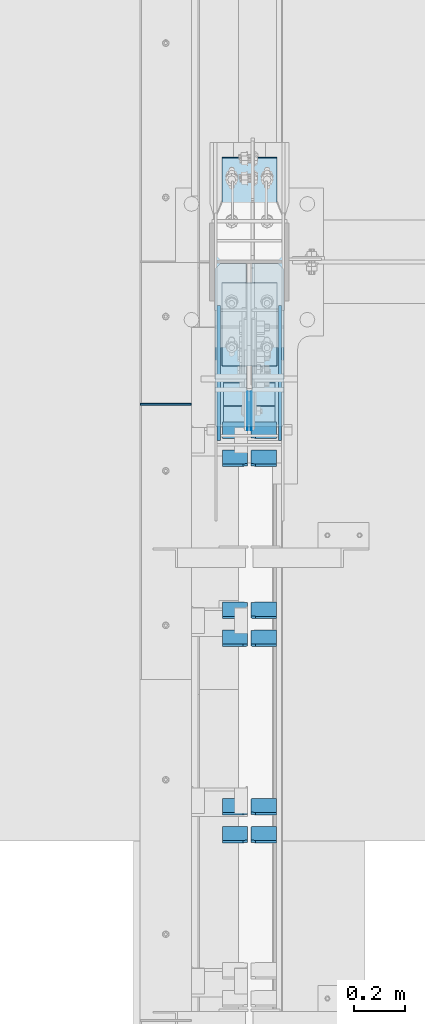
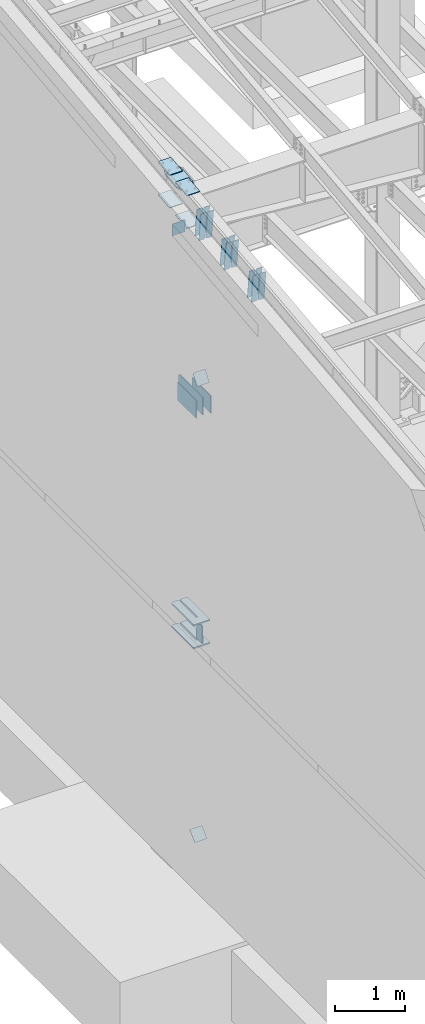
# One storey, part 1015 of 1179: 27 plates, 6 elements without a shape of their own.
"""IFC2X3 building model written with IfcOpenShell, lengths in millimetres."""

from ifc_helpers import new_model, si_unit, frame, origin_with_axes, place, context, subcontext, project, spatial, faceted_brep, material, type_object, element, aggregate, save


model = new_model("IFC2X3")

# Units and contexts
model_context = context("Model", 3, precision=1e-05, world=origin_with_axes())
body_context = subcontext(model_context, "Body", "Model", "MODEL_VIEW")
ifc_project = project(units=[si_unit("LENGTHUNIT", "METRE", prefix="MILLI"), si_unit("AREAUNIT", "SQUARE_METRE"), si_unit("VOLUMEUNIT", "CUBIC_METRE"), si_unit("MASSUNIT", "GRAM", prefix="KILO"), si_unit("TIMEUNIT", "SECOND"), si_unit("PLANEANGLEUNIT", "RADIAN"), si_unit("SOLIDANGLEUNIT", "STERADIAN"), si_unit("THERMODYNAMICTEMPERATUREUNIT", "DEGREE_CELSIUS"), si_unit("LUMINOUSINTENSITYUNIT", "LUMEN")], contexts=[model_context])

# Site, building, storey
site_placement = place(None, origin_with_axes())
site = spatial("IfcSite", under=ifc_project, at=site_placement, CompositionType="ELEMENT")
building_placement = place(site_placement, origin_with_axes())
building = spatial("IfcBuilding", under=site, at=building_placement, Name="Undefined", CompositionType="ELEMENT")
storey_placement = place(building_placement, origin_with_axes())
storey = spatial("IfcBuildingStorey", under=building, at=storey_placement, Name="Undefined", CompositionType="ELEMENT", Elevation=0.0)

# Assembly, plates
assembly_1_placement = place(storey_placement, origin_with_axes())
assembly_1 = element("IfcElementAssembly", 1, at=assembly_1_placement, inside=storey, Name="COLUMN", AssemblyPlace="NOTDEFINED", PredefinedType="RIGID_FRAME")
ifc_material_1 = material(Name="STEEL/A572-GR.50")
plate_type_1 = type_object("IfcPlateType", PredefinedType="NOTDEFINED")
plate_1_placement = place(assembly_1_placement, frame((295.275012207031, 18575.0015696625, 3694.1125), z_axis=(0.0, 1.0, 0.0), x_axis=(1.0, 0.0, 0.0)))
plate_1 = element("IfcPlate", 2, at=plate_1_placement, type_object=plate_type_1, material=ifc_material_1, Name="PLATE", context=body_context, shape_type="Brep", body=[
    faceted_brep([(125.412487792968, -11.1125000000002, 646.448430322878), (125.412487792968, -11.1125000000002, 153.987500190735), (125.412487792968, 11.1125000000002, 153.987500190735), (125.412487792968, 11.1125000000002, 646.448430322878), (126.258376502454, -11.1125000000002, 149.734930475586), (126.258376502454, 11.1125000000002, 149.734930475586), (128.667263742896, -11.1125000000002, 146.12977594993), (128.667263742896, 11.1125000000002, 146.12977594993), (132.272418268556, -11.1125000000002, 143.720888709488), (132.272418268556, 11.1125000000002, 143.720888709488), (136.524987602239, -11.1125000000002, 142.875), (136.524987602239, 11.1125000000002, 142.875), (140.777557317386, -11.1125000000002, 143.720888709488), (140.777557317386, 11.1125000000002, 143.720888709488), (144.382711843045, -11.1125000000002, 146.12977594993), (144.382711843045, 11.1125000000002, 146.12977594993), (146.791599083488, -11.1125000000002, 149.734930475586), (146.791599083488, 11.1125000000002, 149.734930475586), (147.637487792974, -11.1125000000002, 153.987500190735), (147.637487792974, 11.1125000000002, 153.987500190735), (147.637487792974, -11.1125000000002, 646.448430322878), (147.637487792974, 11.1125000000002, 646.448430322878), (0.0, -11.1125000000002, 624.223429941409), (22.2250003814697, -11.1125000000002, 646.448430322878), (22.2250003814697, 11.1125000000002, 646.448430322878), (0.0, 11.1125000000002, 624.223429941409), (0.0, -11.1125000000002, 15.875), (0.0, 11.1125000000002, 15.875), (6.34999990463257, -11.1125000000002, 0.0), (6.34999990463257, 11.1125000000002, 0.0), (266.699987888336, -11.1125000000002, 0.0), (266.699987888336, 11.1125000000002, 0.0), (273.049987792969, -11.1125000000002, 15.875), (273.049987792969, 11.1125000000002, 15.875), (273.049987792969, -11.1125000000002, 624.223429941409), (273.049987792969, 11.1125000000002, 624.223429941409), (250.824987411499, -11.1125000000002, 646.448430322878), (250.824987411499, 11.1125000000002, 646.448430322878)], [[[0, 1, 2, 3]], [[4, 5, 2, 1]], [[6, 7, 5, 4]], [[8, 9, 7, 6]], [[10, 11, 9, 8]], [[12, 13, 11, 10]], [[14, 15, 13, 12]], [[16, 17, 15, 14]], [[18, 19, 17, 16]], [[20, 21, 19, 18]], [[22, 23, 24, 25]], [[26, 22, 25, 27]], [[28, 26, 27, 29]], [[30, 28, 29, 31]], [[32, 30, 31, 33]], [[34, 32, 33, 35]], [[36, 34, 35, 37]], [[16, 14, 12, 10, 8, 6, 4, 1, 0, 23, 22, 26, 28, 30, 32, 34, 36, 20, 18]], [[24, 23, 0, 3]], [[37, 35, 33, 31, 29, 27, 25, 24, 3, 2, 5, 7, 9, 11, 13, 15, 17, 19, 21]], [[36, 37, 21, 20]]]),
])
plate_2_placement = place(assembly_1_placement, frame((295.275012207031, 18575.0015696625, 4090.9875), z_axis=(0.0, 1.0, 0.0), x_axis=(1.0, 0.0, 0.0)))
plate_2 = element("IfcPlate", 3, at=plate_2_placement, type_object=plate_type_1, material=ifc_material_1, Name="PLATE", context=body_context, shape_type="Brep", body=[
    faceted_brep([(125.412487792968, -11.1125000000002, 646.448430322878), (125.412487792968, -11.1125000000002, 153.987500190735), (125.412487792968, 11.1125000000002, 153.987500190735), (125.412487792968, 11.1125000000002, 646.448430322878), (126.258376502454, -11.1125000000002, 149.734930475586), (126.258376502454, 11.1125000000002, 149.734930475586), (128.667263742896, -11.1125000000002, 146.12977594993), (128.667263742896, 11.1125000000002, 146.12977594993), (132.272418268556, -11.1125000000002, 143.720888709488), (132.272418268556, 11.1125000000002, 143.720888709488), (136.524987602239, -11.1125000000002, 142.875), (136.524987602239, 11.1125000000002, 142.875), (140.777557317386, -11.1125000000002, 143.720888709488), (140.777557317386, 11.1125000000002, 143.720888709488), (144.382711843045, -11.1125000000002, 146.12977594993), (144.382711843045, 11.1125000000002, 146.12977594993), (146.791599083488, -11.1125000000002, 149.734930475586), (146.791599083488, 11.1125000000002, 149.734930475586), (147.637487792974, -11.1125000000002, 153.987500190735), (147.637487792974, 11.1125000000002, 153.987500190735), (147.637487792974, -11.1125000000002, 646.448430322878), (147.637487792974, 11.1125000000002, 646.448430322878), (0.0, -11.1125000000002, 624.223429941409), (22.2250003814697, -11.1125000000002, 646.448430322878), (22.2250003814697, 11.1125000000002, 646.448430322878), (0.0, 11.1125000000002, 624.223429941409), (0.0, -11.1125000000002, 15.875), (0.0, 11.1125000000002, 15.875), (6.34999990463257, -11.1125000000002, 0.0), (6.34999990463257, 11.1125000000002, 0.0), (266.699987888336, -11.1125000000002, 0.0), (266.699987888336, 11.1125000000002, 0.0), (273.049987792969, -11.1125000000002, 15.875), (273.049987792969, 11.1125000000002, 15.875), (273.049987792969, -11.1125000000002, 624.223429941409), (273.049987792969, 11.1125000000002, 624.223429941409), (250.824987411499, -11.1125000000002, 646.448430322878), (250.824987411499, 11.1125000000002, 646.448430322878)], [[[0, 1, 2, 3]], [[4, 5, 2, 1]], [[6, 7, 5, 4]], [[8, 9, 7, 6]], [[10, 11, 9, 8]], [[12, 13, 11, 10]], [[14, 15, 13, 12]], [[16, 17, 15, 14]], [[18, 19, 17, 16]], [[20, 21, 19, 18]], [[22, 23, 24, 25]], [[26, 22, 25, 27]], [[28, 26, 27, 29]], [[30, 28, 29, 31]], [[32, 30, 31, 33]], [[34, 32, 33, 35]], [[36, 34, 35, 37]], [[16, 14, 12, 10, 8, 6, 4, 1, 0, 23, 22, 26, 28, 30, 32, 34, 36, 20, 18]], [[24, 23, 0, 3]], [[37, 35, 33, 31, 29, 27, 25, 24, 3, 2, 5, 7, 9, 11, 13, 15, 17, 19, 21]], [[36, 37, 21, 20]]]),
])

# Assembly, plate
assembly_2_placement = place(storey_placement, origin_with_axes())
assembly_2 = element("IfcElementAssembly", 4, at=assembly_2_placement, inside=storey, Name="BEAM", AssemblyPlace="NOTDEFINED", PredefinedType="RIGID_FRAME")
ifc_material_2 = material(Name="STEEL/A36")
plate_type_2 = type_object("IfcPlateType", PredefinedType="NOTDEFINED")
plate_3_placement = place(assembly_2_placement, frame((0.0, 18665.8250005413, 11099.2055869157), z_axis=(0.0, 0.0, -1.0), x_axis=(1.0, 0.0, 0.0)))
plate_3 = element("IfcPlate", 5, at=plate_3_placement, type_object=plate_type_2, material=ifc_material_2, Name="CAP_PLATE", context=body_context, shape_type="Brep", body=[
    faceted_brep([(0.0, -3.17500000000109, 0.0), (0.0, -3.17499999999927, 204.492999998953), (0.0, 3.17499999999927, 204.492999998953), (0.0, 3.17500000000109, 7.27595761418343e-12), (203.199999999997, -3.17499999999927, 204.492999998953), (203.199999999997, 3.17499999999927, 204.492999998953), (203.199999999997, -3.17499999999927, 3.63797880709171e-12), (203.199999999997, 3.17499999999382, -3.63797880709171e-12)], [[[0, 1, 2, 3]], [[1, 4, 5, 2]], [[4, 6, 7, 5]], [[6, 0, 3, 7]], [[5, 7, 3, 2]], [[6, 4, 1, 0]]]),
])
aggregate(assembly_2, [plate_3])

assembly_3_placement = place(storey_placement, origin_with_axes())
assembly_3 = element("IfcElementAssembly", 6, at=assembly_3_placement, inside=storey, Name="Plate", AssemblyPlace="NOTDEFINED", PredefinedType="RIGID_FRAME")
plate_4_placement = place(assembly_3_placement, frame((330.200000000002, 18538.1072747927, 8241.67561343987), z_axis=(0.0, 0.591856615182528, 0.806043266248581), x_axis=(1.0, 0.0, 0.0)))
plate_4 = element("IfcPlate", 7, at=plate_4_placement, type_object=plate_type_2, material=ifc_material_2, Name="Plate", context=body_context, shape_type="Brep", body=[
    faceted_brep([(0.0, -3.17500000000109, 0.0), (0.0, -3.17500000000291, 203.200000000368), (0.0, 3.17499999998836, 203.200000000361), (0.0, 3.17500000000109, 7.27595761418343e-12), (203.199999999997, -3.17500000000291, 203.200000000368), (203.199999999997, 3.17499999998836, 203.200000000361), (203.199999999997, -3.17499999999927, 3.63797880709171e-12), (203.199999999997, 3.17499999999382, -3.63797880709171e-12)], [[[0, 1, 2, 3]], [[1, 4, 5, 2]], [[4, 6, 7, 5]], [[6, 0, 3, 7]], [[5, 7, 3, 2]], [[6, 4, 1, 0]]]),
])
aggregate(assembly_3, [plate_4])

assembly_4_placement = place(storey_placement, origin_with_axes())
assembly_4 = element("IfcElementAssembly", 8, at=assembly_4_placement, inside=storey, Name="Plate", AssemblyPlace="NOTDEFINED", PredefinedType="RIGID_FRAME")
plate_5_placement = place(assembly_4_placement, frame((330.200000000002, 18604.2796707284, 297.334563911106), z_axis=(0.0, 0.727605443744036, 0.68599585875867), x_axis=(1.0, 0.0, 0.0)))
plate_5 = element("IfcPlate", 9, at=plate_5_placement, type_object=plate_type_2, material=ifc_material_2, Name="Plate", context=body_context, shape_type="Brep", body=[
    faceted_brep([(0.0, -3.17500000000109, 0.0), (0.0, -3.17500000000291, 203.200000000368), (0.0, 3.17499999998836, 203.200000000361), (0.0, 3.17500000000109, 7.27595761418343e-12), (203.199999999997, -3.17500000000291, 203.200000000368), (203.199999999997, 3.17499999998836, 203.200000000361), (203.199999999997, -3.17499999999927, 3.63797880709171e-12), (203.199999999997, 3.17499999999382, -3.63797880709171e-12)], [[[0, 1, 2, 3]], [[1, 4, 5, 2]], [[4, 6, 7, 5]], [[6, 0, 3, 7]], [[5, 7, 3, 2]], [[6, 4, 1, 0]]]),
])
aggregate(assembly_4, [plate_5])

# Plate
plate_type_3 = type_object("IfcPlateType", PredefinedType="NOTDEFINED")
plate_6_placement = place(assembly_1_placement, frame((431.799999999999, 18545.3498035139, 8013.7), z_axis=(0.0, 0.0, -1.0), x_axis=(0.0, 1.0, 0.0)))
plate_6 = element("IfcPlate", 10, at=plate_6_placement, type_object=plate_type_3, material=ifc_material_1, Name="PLATE", context=body_context, shape_type="Brep", body=[
    faceted_brep([(0.0, -9.52499999999964, 0.0), (0.0, -9.52499999999998, 304.799999999999), (0.0, 9.52499999999998, 304.799999999999), (0.0, 9.52499999999964, 0.0), (657.050197249024, -9.52499999999998, 304.799999999999), (657.050197249024, 9.52499999999998, 304.799999999999), (676.100196486084, -9.52499999999998, 285.750000762939), (676.100196486084, 9.52499999999998, 285.750000762939), (676.100196486084, -9.52499999999998, 19.0499992370605), (676.100196486084, 9.52499999999998, 19.0499992370605), (657.050197249024, -9.52499999999998, 0.0), (657.050197249024, 9.52499999999998, 0.0)], [[[0, 1, 2, 3]], [[1, 4, 5, 2]], [[4, 6, 7, 5]], [[6, 8, 9, 7]], [[8, 10, 11, 9]], [[10, 0, 3, 11]], [[5, 7, 9, 11, 3, 2]], [[10, 8, 6, 4, 1, 0]]]),
])

plate_type_4 = type_object("IfcPlateType", PredefinedType="NOTDEFINED")
plate_7_placement = place(assembly_1_placement, frame((295.274999999754, 18991.1139130949, 11378.5871510539), z_axis=(1.0, 0.0, 0.0), x_axis=(0.0, 0.993683229349742, 0.112221387039499)))
plate_7 = element("IfcPlate", 11, at=plate_7_placement, type_object=plate_type_4, material=ifc_material_1, Name="PLATE", context=body_context, shape_type="Brep", body=[
    faceted_brep([(404.009737741189, -14.2874999996602, 8.31619217933621e-11), (71.43750000002, -14.287499999984, 2.90469870378729e-11), (71.4375000000155, 14.2874999999949, 2.90469870378729e-11), (404.009737741166, 14.2875000003405, 8.31619217933621e-11), (477.034739267168, 14.2875000004005, 30.162500381568), (473.810043726306, -14.287499999602, 28.8305609300143), (477.034739268025, 14.2875000004024, 242.887499623284), (473.810043726306, -14.287499999602, 244.219439075195), (404.009737742264, 14.2875000003405, 273.05000000474), (404.00973774229, -14.2874999996602, 273.05000000474), (71.4375000016116, -14.2874999999858, 273.049999999798), (71.4375000016071, 14.2874999999967, 273.049999999798), (4.20644072178584, 14.2875000000058, 244.663552394444), (0.979329666730337, -14.2874999999967, 243.30099437618), (0.979329666730337, -14.2874999999967, 29.7490056281208), (4.20644072178584, 14.2875000000058, 28.3864476098539)], [[[0, 1, 2, 3]], [[0, 3, 4, 5]], [[5, 4, 6, 7]], [[8, 9, 7, 6]], [[10, 9, 8, 11]], [[10, 11, 12, 13]], [[1, 0, 5, 7, 9, 10, 13, 14]], [[2, 1, 14, 15]], [[11, 8, 6, 4, 3, 2, 15, 12]], [[14, 13, 12, 15]]]),
])

# Assembly, plates
assembly_5_placement = place(storey_placement, origin_with_axes())
assembly_5 = element("IfcElementAssembly", 12, at=assembly_5_placement, inside=storey, Name="BEAM", AssemblyPlace="NOTDEFINED", PredefinedType="RIGID_FRAME")
plate_type_5 = type_object("IfcPlateType", PredefinedType="NOTDEFINED")
plate_8_placement = place(assembly_5_placement, frame((438.943750000002, 18714.7008203787, 4044.95), z_axis=(0.0, 0.0, -1.0), x_axis=(0.0, -1.0, 0.0)))
plate_8 = element("IfcPlate", 13, at=plate_8_placement, type_object=plate_type_5, material=ifc_material_1, Name="PLATE", context=body_context, shape_type="Brep", body=[
    faceted_brep([(3.63797880709171e-12, -1.58750000000055, 1.81898940354586e-12), (-2.18278728425503e-11, -1.58750000000146, 304.8), (-2.18278728425503e-11, 1.58750000000146, 304.8), (-3.63797880709171e-12, 1.58750000000055, 0.0), (152.399999999994, -1.58750000000146, 304.8), (152.399999999994, 1.58750000000146, 304.8), (152.399999999994, -1.58750000000146, 0.0), (152.399999999994, 1.58750000000146, 0.0)], [[[0, 1, 2, 3]], [[1, 4, 5, 2]], [[4, 6, 7, 5]], [[6, 0, 3, 7]], [[5, 7, 3, 2]], [[6, 4, 1, 0]]]),
])
plate_9_placement = place(assembly_5_placement, frame((424.656250000002, 18714.7008203787, 4044.95), z_axis=(0.0, 0.0, -1.0), x_axis=(0.0, -1.0, 0.0)))
plate_9 = element("IfcPlate", 14, at=plate_9_placement, type_object=plate_type_5, material=ifc_material_1, Name="PLATE", context=body_context, shape_type="Brep", body=[
    faceted_brep([(3.63797880709171e-12, -1.58750000000055, 1.81898940354586e-12), (-2.18278728425503e-11, -1.58750000000146, 304.8), (-2.18278728425503e-11, 1.58750000000146, 304.8), (-3.63797880709171e-12, 1.58750000000055, 0.0), (152.399999999994, -1.58750000000146, 304.8), (152.399999999994, 1.58750000000146, 304.8), (152.399999999994, -1.58750000000146, 0.0), (152.399999999994, 1.58750000000146, 0.0)], [[[0, 1, 2, 3]], [[1, 4, 5, 2]], [[4, 6, 7, 5]], [[6, 0, 3, 7]], [[5, 7, 3, 2]], [[6, 4, 1, 0]]]),
])
aggregate(assembly_5, [plate_8, plate_9])

# Plate
plate_type_6 = type_object("IfcPlateType", PredefinedType="NOTDEFINED")
plate_10_placement = place(assembly_1_placement, frame((552.450000000001, 18523.1248035139, 8013.7), z_axis=(0.0, 0.0, -1.0), x_axis=(0.0, 1.0, 0.0)))
plate_10 = element("IfcPlate", 15, at=plate_10_placement, type_object=plate_type_6, material=ifc_material_1, Name="PLATE", context=body_context, shape_type="Brep", body=[
    faceted_brep([(0.0, -6.34999999999854, 0.0), (0.0, -6.34999999999854, 304.799999999999), (0.0, 6.34999999999854, 304.799999999999), (0.0, 6.34999999999854, 0.0), (531.637696486086, -6.34999999999854, 304.799999999999), (531.637696486086, 6.34999999999854, 304.799999999999), (531.637696486086, -6.34999999999854, 0.0), (531.637696486086, 6.34999999999854, 0.0)], [[[0, 1, 2, 3]], [[1, 4, 5, 2]], [[4, 6, 7, 5]], [[6, 0, 3, 7]], [[5, 7, 3, 2]], [[6, 4, 1, 0]]]),
])

plate_11_placement = place(assembly_1_placement, frame((311.150000000001, 18523.1248035139, 8013.7), z_axis=(0.0, 0.0, -1.0), x_axis=(0.0, 1.0, 0.0)))
plate_11 = element("IfcPlate", 16, at=plate_11_placement, type_object=plate_type_6, material=ifc_material_1, Name="PLATE", context=body_context, shape_type="Brep", body=[
    faceted_brep([(0.0, -6.34999999999854, 0.0), (0.0, -6.34999999999854, 304.799999999999), (0.0, 6.34999999999854, 304.799999999999), (0.0, 6.34999999999854, 0.0), (531.637696486086, -6.34999999999854, 304.799999999999), (531.637696486086, 6.34999999999854, 304.799999999999), (531.637696486086, -6.34999999999854, 0.0), (531.637696486086, 6.34999999999854, 0.0)], [[[0, 1, 2, 3]], [[1, 4, 5, 2]], [[4, 6, 7, 5]], [[6, 0, 3, 7]], [[5, 7, 3, 2]], [[6, 4, 1, 0]]]),
])

plate_type_7 = type_object("IfcPlateType", PredefinedType="NOTDEFINED")
plate_12_placement = place(assembly_1_placement, frame((323.850003077961, 19638.8732407573, 11472.5223933958), z_axis=(1.0, 0.0, 0.0), x_axis=(0.0, -0.993676146336441, -0.112284087038017)))
plate_12 = element("IfcPlate", 17, at=plate_12_placement, type_object=plate_type_7, material=ifc_material_1, Name="PLATE", context=body_context, shape_type="Brep", body=[
    faceted_brep([(0.0, -6.34999999999854, 0.0), (0.0, -6.350000000004, 215.899993896484), (0.0, 6.35000000000582, 215.899993896484), (0.0, 6.34999999999854, 0.0), (330.200000001782, -6.34999999994034, 215.899993896483), (330.200000001782, 6.35000000006767, 215.899993896483), (330.200000001782, -6.34999999994034, -1.47792889038101e-12), (330.200000001782, 6.35000000006767, -1.47792889038101e-12)], [[[0, 1, 2, 3]], [[1, 4, 5, 2]], [[4, 6, 7, 5]], [[6, 0, 3, 7]], [[5, 7, 3, 2]], [[6, 4, 1, 0]]]),
])

plate_13_placement = place(assembly_1_placement, frame((323.850003068444, 18816.8882512744, 11379.6391794643), z_axis=(1.0, 0.0, 0.0), x_axis=(0.0, 0.993676146336441, 0.112284087038017)))
plate_13 = element("IfcPlate", 18, at=plate_13_placement, type_object=plate_type_7, material=ifc_material_1, Name="PLATE", context=body_context, shape_type="Brep", body=[
    faceted_brep([(0.0, -6.34999999999854, 0.0), (0.0, -6.350000000004, 215.899993896484), (0.0, 6.35000000000582, 215.899993896484), (0.0, 6.34999999999854, 0.0), (330.200000001782, -6.34999999994034, 215.899993896483), (330.200000001782, 6.35000000006767, 215.899993896483), (330.200000001782, -6.34999999994034, -1.47792889038101e-12), (330.200000001782, 6.35000000006767, -1.47792889038101e-12)], [[[0, 1, 2, 3]], [[1, 4, 5, 2]], [[4, 6, 7, 5]], [[6, 0, 3, 7]], [[5, 7, 3, 2]], [[6, 4, 1, 0]]]),
])

plate_14_placement = place(assembly_1_placement, frame((323.850003061394, 19640.2992486357, 10907.0468457172), z_axis=(1.0, 0.0, 0.0), x_axis=(0.0, -0.993676146336441, -0.112284087038017)))
plate_14 = element("IfcPlate", 19, at=plate_14_placement, type_object=plate_type_7, material=ifc_material_1, Name="PLATE", context=body_context, shape_type="Brep", body=[
    faceted_brep([(0.0, -6.34999999999854, 0.0), (0.0, -6.350000000004, 215.899993896484), (0.0, 6.35000000000582, 215.899993896484), (0.0, 6.34999999999854, 0.0), (330.200000001782, -6.34999999994034, 215.899993896483), (330.200000001782, 6.35000000006767, 215.899993896483), (330.200000001782, -6.34999999994034, -1.47792889038101e-12), (330.200000001782, 6.35000000006767, -1.47792889038101e-12)], [[[0, 1, 2, 3]], [[1, 4, 5, 2]], [[4, 6, 7, 5]], [[6, 0, 3, 7]], [[5, 7, 3, 2]], [[6, 4, 1, 0]]]),
])

plate_15_placement = place(assembly_1_placement, frame((323.850003041494, 18817.5392708174, 10814.0760589973), z_axis=(1.0, 0.0, 0.0), x_axis=(0.0, 0.993676146336441, 0.112284087038017)))
plate_15 = element("IfcPlate", 20, at=plate_15_placement, type_object=plate_type_7, material=ifc_material_1, Name="PLATE", context=body_context, shape_type="Brep", body=[
    faceted_brep([(0.0, -6.34999999999854, 0.0), (0.0, -6.350000000004, 215.899993896484), (0.0, 6.35000000000582, 215.899993896484), (0.0, 6.34999999999854, 0.0), (330.200000001782, -6.34999999994034, 215.899993896483), (330.200000001782, 6.35000000006767, 215.899993896483), (330.200000001782, -6.34999999994034, -1.47792889038101e-12), (330.200000001782, 6.35000000006767, -1.47792889038101e-12)], [[[0, 1, 2, 3]], [[1, 4, 5, 2]], [[4, 6, 7, 5]], [[6, 0, 3, 7]], [[5, 7, 3, 2]], [[6, 4, 1, 0]]]),
])

aggregate(assembly_1, [plate_6, plate_10, plate_11, plate_1, plate_2, plate_12, plate_13, plate_7, plate_14, plate_15])

# Assembly, plates
assembly_6_placement = place(storey_placement, origin_with_axes())
assembly_6 = element("IfcElementAssembly", 21, at=assembly_6_placement, inside=storey, Name="BEAM", AssemblyPlace="NOTDEFINED", PredefinedType="RIGID_FRAME")
plate_type_8 = type_object("IfcPlateType", PredefinedType="NOTDEFINED")
plate_16_placement = place(assembly_6_placement, frame((538.162500000002, 16995.0165896219, 10640.0854731204), z_axis=(0.0, -0.112284087038017, 0.993676146336441), x_axis=(-1.0, 0.0, 0.0)))
plate_16 = element("IfcPlate", 22, at=plate_16_placement, type_object=plate_type_8, material=ifc_material_2, Name="PLATE", context=body_context, shape_type="Brep", body=[
    faceted_brep([(0.0, -4.76249999999709, 0.0), (0.0, -4.76250000020082, 498.474999998594), (0.0, 4.76249999979336, 498.474999998596), (0.0, 4.76249999999709, 0.0), (81.7562503814697, -4.76250000020082, 498.474999998594), (81.7562503814697, 4.76249999979336, 498.474999998596), (99.21875, -4.76250000019354, 481.012500380073), (99.21875, 4.76249999980064, 481.012500380079), (99.21875, -4.76250000000437, 17.4624996185212), (99.21875, 4.76249999998981, 17.4624996185248), (81.7562503814697, -4.76250000000073, 0.0), (81.7562503814697, 4.76249999999709, 3.63797880709171e-12)], [[[0, 1, 2, 3]], [[1, 4, 5, 2]], [[4, 6, 7, 5]], [[6, 8, 9, 7]], [[8, 10, 11, 9]], [[10, 0, 3, 11]], [[5, 7, 9, 11, 3, 2]], [[10, 8, 6, 4, 1, 0]]]),
])
plate_17_placement = place(assembly_6_placement, frame((424.656250000002, 16995.0165896219, 10640.0854731204), z_axis=(0.0, -0.112284087038017, 0.993676146336441), x_axis=(-1.0, 0.0, 0.0)))
plate_17 = element("IfcPlate", 23, at=plate_17_placement, type_object=plate_type_8, material=ifc_material_2, Name="PLATE", context=body_context, shape_type="Brep", body=[
    faceted_brep([(-1.81898940354586e-12, -4.76249999999345, 17.4624996185303), (0.0, -4.76250000019354, 481.012500380073), (0.0, 4.76249999980064, 481.012500380079), (1.81898940354586e-12, 4.76250000000073, 17.4624996185303), (17.4624996185303, -4.76250000020082, 498.474999998594), (17.4624996185303, 4.76249999979336, 498.474999998596), (99.2187497618652, -4.76249999998072, 498.475), (99.2187499999927, 4.76250000001892, 498.475), (99.21875, -4.76250000000073, 0.0), (99.21875, 4.76249999999709, 3.63797880709171e-12), (17.4624996185157, -4.76250000000073, 0.0), (17.4624996185212, 4.76249999999345, 0.0)], [[[0, 1, 2, 3]], [[1, 4, 5, 2]], [[4, 6, 7, 5]], [[6, 8, 9, 7]], [[8, 10, 11, 9]], [[10, 0, 3, 11]], [[5, 7, 9, 11, 3, 2]], [[10, 8, 6, 4, 1, 0]]]),
])
plate_18_placement = place(assembly_6_placement, frame((538.162500000002, 17105.4388513835, 10652.5630422924), z_axis=(0.0, -0.112284087038017, 0.993676146336441), x_axis=(-1.0, 0.0, 0.0)))
plate_18 = element("IfcPlate", 24, at=plate_18_placement, type_object=plate_type_8, material=ifc_material_2, Name="PLATE", context=body_context, shape_type="Brep", body=[
    faceted_brep([(0.0, -4.76249999999709, 0.0), (0.0, -4.76250000020082, 498.474999998594), (0.0, 4.76249999979336, 498.474999998596), (0.0, 4.76249999999709, 0.0), (81.7562503814697, -4.76250000020082, 498.474999998594), (81.7562503814697, 4.76249999979336, 498.474999998596), (99.21875, -4.76250000019354, 481.012500380073), (99.21875, 4.76249999980064, 481.012500380079), (99.21875, -4.76250000000437, 17.4624996185212), (99.21875, 4.76249999998981, 17.4624996185248), (81.7562503814697, -4.76250000000073, 0.0), (81.7562503814697, 4.76249999999709, 3.63797880709171e-12)], [[[0, 1, 2, 3]], [[1, 4, 5, 2]], [[4, 6, 7, 5]], [[6, 8, 9, 7]], [[8, 10, 11, 9]], [[10, 0, 3, 11]], [[5, 7, 9, 11, 3, 2]], [[10, 8, 6, 4, 1, 0]]]),
])
plate_19_placement = place(assembly_6_placement, frame((424.656250000002, 17105.4388513835, 10652.5630422924), z_axis=(0.0, -0.112284087038017, 0.993676146336441), x_axis=(-1.0, 0.0, 0.0)))
plate_19 = element("IfcPlate", 25, at=plate_19_placement, type_object=plate_type_8, material=ifc_material_2, Name="PLATE", context=body_context, shape_type="Brep", body=[
    faceted_brep([(-1.81898940354586e-12, -4.76249999999345, 17.4624996185303), (0.0, -4.76250000019354, 481.012500380073), (0.0, 4.76249999980064, 481.012500380079), (1.81898940354586e-12, 4.76250000000073, 17.4624996185303), (17.4624996185303, -4.76250000020082, 498.474999998594), (17.4624996185303, 4.76249999979336, 498.474999998596), (99.2187497618652, -4.76249999998072, 498.475), (99.2187499999927, 4.76250000001892, 498.475), (99.21875, -4.76250000000073, 0.0), (99.21875, 4.76249999999709, 3.63797880709171e-12), (17.4624996185157, -4.76250000000073, 0.0), (17.4624996185212, 4.76249999999345, 0.0)], [[[0, 1, 2, 3]], [[1, 4, 5, 2]], [[4, 6, 7, 5]], [[6, 8, 9, 7]], [[8, 10, 11, 9]], [[10, 0, 3, 11]], [[5, 7, 9, 11, 3, 2]], [[10, 8, 6, 4, 1, 0]]]),
])
plate_20_placement = place(assembly_6_placement, frame((538.162500000002, 17769.5084843946, 10727.602030344), z_axis=(0.0, -0.112284087038017, 0.993676146336441), x_axis=(-1.0, 0.0, 0.0)))
plate_20 = element("IfcPlate", 26, at=plate_20_placement, type_object=plate_type_8, material=ifc_material_2, Name="PLATE", context=body_context, shape_type="Brep", body=[
    faceted_brep([(0.0, -4.76249999999709, 0.0), (0.0, -4.76250000020082, 498.474999998594), (0.0, 4.76249999979336, 498.474999998596), (0.0, 4.76249999999709, 0.0), (81.7562503814697, -4.76250000020082, 498.474999998594), (81.7562503814697, 4.76249999979336, 498.474999998596), (99.21875, -4.76250000019354, 481.012500380073), (99.21875, 4.76249999980064, 481.012500380079), (99.21875, -4.76250000000437, 17.4624996185212), (99.21875, 4.76249999998981, 17.4624996185248), (81.7562503814697, -4.76250000000073, 0.0), (81.7562503814697, 4.76249999999709, 3.63797880709171e-12)], [[[0, 1, 2, 3]], [[1, 4, 5, 2]], [[4, 6, 7, 5]], [[6, 8, 9, 7]], [[8, 10, 11, 9]], [[10, 0, 3, 11]], [[5, 7, 9, 11, 3, 2]], [[10, 8, 6, 4, 1, 0]]]),
])
plate_21_placement = place(assembly_6_placement, frame((424.656250000002, 17769.5084843946, 10727.602030344), z_axis=(0.0, -0.112284087038017, 0.993676146336441), x_axis=(-1.0, 0.0, 0.0)))
plate_21 = element("IfcPlate", 27, at=plate_21_placement, type_object=plate_type_8, material=ifc_material_2, Name="PLATE", context=body_context, shape_type="Brep", body=[
    faceted_brep([(-1.81898940354586e-12, -4.76249999999345, 17.4624996185303), (0.0, -4.76250000019354, 481.012500380073), (0.0, 4.76249999980064, 481.012500380079), (1.81898940354586e-12, 4.76250000000073, 17.4624996185303), (17.4624996185303, -4.76250000020082, 498.474999998594), (17.4624996185303, 4.76249999979336, 498.474999998596), (99.2187497618652, -4.76249999998072, 498.475), (99.2187499999927, 4.76250000001892, 498.475), (99.21875, -4.76250000000073, 0.0), (99.21875, 4.76249999999709, 3.63797880709171e-12), (17.4624996185157, -4.76250000000073, 0.0), (17.4624996185212, 4.76249999999345, 0.0)], [[[0, 1, 2, 3]], [[1, 4, 5, 2]], [[4, 6, 7, 5]], [[6, 8, 9, 7]], [[8, 10, 11, 9]], [[10, 0, 3, 11]], [[5, 7, 9, 11, 3, 2]], [[10, 8, 6, 4, 1, 0]]]),
])
plate_22_placement = place(assembly_6_placement, frame((538.162500000002, 17879.9307461562, 10740.079599516), z_axis=(0.0, -0.112284087038017, 0.993676146336441), x_axis=(-1.0, 0.0, 0.0)))
plate_22 = element("IfcPlate", 28, at=plate_22_placement, type_object=plate_type_8, material=ifc_material_2, Name="PLATE", context=body_context, shape_type="Brep", body=[
    faceted_brep([(0.0, -4.76249999999709, 0.0), (0.0, -4.76250000020082, 498.474999998594), (0.0, 4.76249999979336, 498.474999998596), (0.0, 4.76249999999709, 0.0), (81.7562503814697, -4.76250000020082, 498.474999998594), (81.7562503814697, 4.76249999979336, 498.474999998596), (99.21875, -4.76250000019354, 481.012500380073), (99.21875, 4.76249999980064, 481.012500380079), (99.21875, -4.76250000000437, 17.4624996185212), (99.21875, 4.76249999998981, 17.4624996185248), (81.7562503814697, -4.76250000000073, 0.0), (81.7562503814697, 4.76249999999709, 3.63797880709171e-12)], [[[0, 1, 2, 3]], [[1, 4, 5, 2]], [[4, 6, 7, 5]], [[6, 8, 9, 7]], [[8, 10, 11, 9]], [[10, 0, 3, 11]], [[5, 7, 9, 11, 3, 2]], [[10, 8, 6, 4, 1, 0]]]),
])
plate_23_placement = place(assembly_6_placement, frame((424.656250000002, 17879.9307461562, 10740.079599516), z_axis=(0.0, -0.112284087038017, 0.993676146336441), x_axis=(-1.0, 0.0, 0.0)))
plate_23 = element("IfcPlate", 29, at=plate_23_placement, type_object=plate_type_8, material=ifc_material_2, Name="PLATE", context=body_context, shape_type="Brep", body=[
    faceted_brep([(-1.81898940354586e-12, -4.76249999999345, 17.4624996185303), (0.0, -4.76250000019354, 481.012500380073), (0.0, 4.76249999980064, 481.012500380079), (1.81898940354586e-12, 4.76250000000073, 17.4624996185303), (17.4624996185303, -4.76250000020082, 498.474999998594), (17.4624996185303, 4.76249999979336, 498.474999998596), (99.2187497618652, -4.76249999998072, 498.475), (99.2187499999927, 4.76250000001892, 498.475), (99.21875, -4.76250000000073, 0.0), (99.21875, 4.76249999999709, 3.63797880709171e-12), (17.4624996185157, -4.76250000000073, 0.0), (17.4624996185212, 4.76249999999345, 0.0)], [[[0, 1, 2, 3]], [[1, 4, 5, 2]], [[4, 6, 7, 5]], [[6, 8, 9, 7]], [[8, 10, 11, 9]], [[10, 0, 3, 11]], [[5, 7, 9, 11, 3, 2]], [[10, 8, 6, 4, 1, 0]]]),
])
plate_24_placement = place(assembly_6_placement, frame((538.162500000002, 18481.1456193623, 10808.0160830477), z_axis=(0.0, -0.112284087038017, 0.993676146336441), x_axis=(-1.0, 0.0, 0.0)))
plate_24 = element("IfcPlate", 30, at=plate_24_placement, type_object=plate_type_8, material=ifc_material_2, Name="PLATE", context=body_context, shape_type="Brep", body=[
    faceted_brep([(0.0, -4.76249999999709, 0.0), (0.0, -4.76250000020082, 498.474999998594), (0.0, 4.76249999979336, 498.474999998596), (0.0, 4.76249999999709, 0.0), (81.7562503814697, -4.76250000020082, 498.474999998594), (81.7562503814697, 4.76249999979336, 498.474999998596), (99.21875, -4.76250000019354, 481.012500380073), (99.21875, 4.76249999980064, 481.012500380079), (99.21875, -4.76250000000437, 17.4624996185212), (99.21875, 4.76249999998981, 17.4624996185248), (81.7562503814697, -4.76250000000073, 0.0), (81.7562503814697, 4.76249999999709, 3.63797880709171e-12)], [[[0, 1, 2, 3]], [[1, 4, 5, 2]], [[4, 6, 7, 5]], [[6, 8, 9, 7]], [[8, 10, 11, 9]], [[10, 0, 3, 11]], [[5, 7, 9, 11, 3, 2]], [[10, 8, 6, 4, 1, 0]]]),
])
plate_25_placement = place(assembly_6_placement, frame((424.656250000002, 18481.1456193623, 10808.0160830477), z_axis=(0.0, -0.112284087038017, 0.993676146336441), x_axis=(-1.0, 0.0, 0.0)))
plate_25 = element("IfcPlate", 31, at=plate_25_placement, type_object=plate_type_8, material=ifc_material_2, Name="PLATE", context=body_context, shape_type="Brep", body=[
    faceted_brep([(-1.81898940354586e-12, -4.76249999999345, 17.4624996185303), (0.0, -4.76250000019354, 481.012500380073), (0.0, 4.76249999980064, 481.012500380079), (1.81898940354586e-12, 4.76250000000073, 17.4624996185303), (17.4624996185303, -4.76250000020082, 498.474999998594), (17.4624996185303, 4.76249999979336, 498.474999998596), (99.2187497618652, -4.76249999998072, 498.475), (99.2187499999927, 4.76250000001892, 498.475), (99.21875, -4.76250000000073, 0.0), (99.21875, 4.76249999999709, 3.63797880709171e-12), (17.4624996185157, -4.76250000000073, 0.0), (17.4624996185212, 4.76249999999345, 0.0)], [[[0, 1, 2, 3]], [[1, 4, 5, 2]], [[4, 6, 7, 5]], [[6, 8, 9, 7]], [[8, 10, 11, 9]], [[10, 0, 3, 11]], [[5, 7, 9, 11, 3, 2]], [[10, 8, 6, 4, 1, 0]]]),
])
plate_26_placement = place(assembly_6_placement, frame((538.162500000002, 18591.5678811239, 10820.4936522197), z_axis=(0.0, -0.112284087038017, 0.993676146336441), x_axis=(-1.0, 0.0, 0.0)))
plate_26 = element("IfcPlate", 32, at=plate_26_placement, type_object=plate_type_8, material=ifc_material_2, Name="PLATE", context=body_context, shape_type="Brep", body=[
    faceted_brep([(0.0, -4.76249999999709, 0.0), (0.0, -4.76250000020082, 498.474999998594), (0.0, 4.76249999979336, 498.474999998596), (0.0, 4.76249999999709, 0.0), (81.7562503814697, -4.76250000020082, 498.474999998594), (81.7562503814697, 4.76249999979336, 498.474999998596), (99.21875, -4.76250000019354, 481.012500380073), (99.21875, 4.76249999980064, 481.012500380079), (99.21875, -4.76250000000437, 17.4624996185212), (99.21875, 4.76249999998981, 17.4624996185248), (81.7562503814697, -4.76250000000073, 0.0), (81.7562503814697, 4.76249999999709, 3.63797880709171e-12)], [[[0, 1, 2, 3]], [[1, 4, 5, 2]], [[4, 6, 7, 5]], [[6, 8, 9, 7]], [[8, 10, 11, 9]], [[10, 0, 3, 11]], [[5, 7, 9, 11, 3, 2]], [[10, 8, 6, 4, 1, 0]]]),
])
plate_27_placement = place(assembly_6_placement, frame((424.656250000002, 18591.5678811239, 10820.4936522197), z_axis=(0.0, -0.112284087038017, 0.993676146336441), x_axis=(-1.0, 0.0, 0.0)))
plate_27 = element("IfcPlate", 33, at=plate_27_placement, type_object=plate_type_8, material=ifc_material_2, Name="PLATE", context=body_context, shape_type="Brep", body=[
    faceted_brep([(-1.81898940354586e-12, -4.76249999999345, 17.4624996185303), (0.0, -4.76250000019354, 481.012500380073), (0.0, 4.76249999980064, 481.012500380079), (1.81898940354586e-12, 4.76250000000073, 17.4624996185303), (17.4624996185303, -4.76250000020082, 498.474999998594), (17.4624996185303, 4.76249999979336, 498.474999998596), (99.2187497618652, -4.76249999998072, 498.475), (99.2187499999927, 4.76250000001892, 498.475), (99.21875, -4.76250000000073, 0.0), (99.21875, 4.76249999999709, 3.63797880709171e-12), (17.4624996185157, -4.76250000000073, 0.0), (17.4624996185212, 4.76249999999345, 0.0)], [[[0, 1, 2, 3]], [[1, 4, 5, 2]], [[4, 6, 7, 5]], [[6, 8, 9, 7]], [[8, 10, 11, 9]], [[10, 0, 3, 11]], [[5, 7, 9, 11, 3, 2]], [[10, 8, 6, 4, 1, 0]]]),
])
aggregate(assembly_6, [plate_16, plate_17, plate_18, plate_19, plate_20, plate_21, plate_22, plate_23, plate_24, plate_25, plate_26, plate_27])

save(model, "model.ifc")
